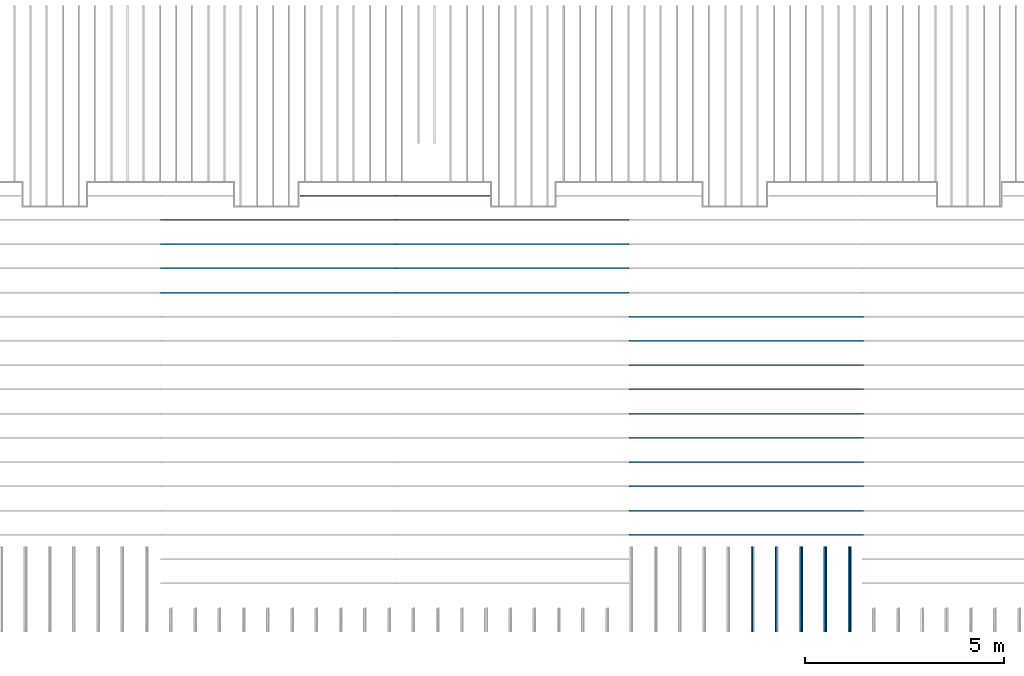
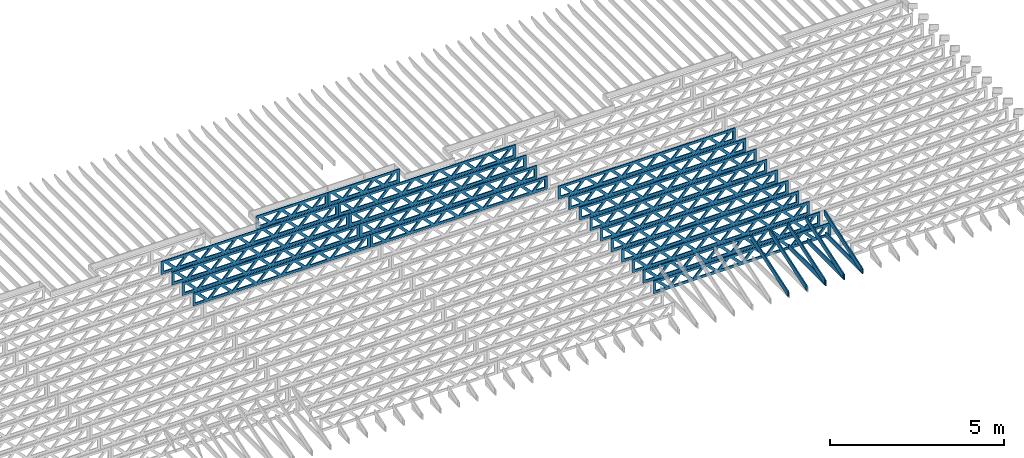
# One storey, part 8 of 17: 28 beams, 5 elements without a shape of their own.
"""IFC4 building model written with IfcOpenShell, lengths in feet."""

from ifc_helpers import new_model, entity, si_unit, converted_unit, derived_unit, direction, frame, frame_2d, origin, origin_2d_with_axis, place, context, subcontext, project, spatial, rectangle, extrude, clip, halfspace, source, transform, mapped, material, material_profile, profile_set, profile_usage, type_object, type_shapes, element, aggregate, save


model = new_model("IFC4")

# Units and contexts
model_context = context("Model", 3, precision=0.0001, world=origin(), true_north=direction((6.12303176911189e-17, 1.0)))
body_context = subcontext(model_context, "Body", "Model", "MODEL_VIEW")
ifc_project = project(units=[converted_unit("LENGTHUNIT", "FOOT", entity("IfcRatioMeasure", 0.3048), si_unit("LENGTHUNIT", "METRE"), dimensions=[1, 0, 0, 0, 0, 0, 0]), converted_unit("AREAUNIT", "SQUARE FOOT", entity("IfcRatioMeasure", 0.09290304), si_unit("AREAUNIT", "SQUARE_METRE"), dimensions=[2, 0, 0, 0, 0, 0, 0]), converted_unit("VOLUMEUNIT", "CUBIC FOOT", entity("IfcRatioMeasure", 0.028316846592), si_unit("VOLUMEUNIT", "CUBIC_METRE"), dimensions=[3, 0, 0, 0, 0, 0, 0]), converted_unit("PLANEANGLEUNIT", "DEGREE", entity("IfcRatioMeasure", 0.0174532925199433), si_unit("PLANEANGLEUNIT", "RADIAN"), dimensions=[0, 0, 0, 0, 0, 0, 0]), si_unit("MASSUNIT", "GRAM", prefix="KILO"), derived_unit("MASSDENSITYUNIT", [(si_unit("MASSUNIT", "GRAM", prefix="KILO"), 1), (si_unit("LENGTHUNIT", "METRE"), -3)]), derived_unit("MOMENTOFINERTIAUNIT", [(si_unit("LENGTHUNIT", "METRE"), 4)]), si_unit("TIMEUNIT", "SECOND"), si_unit("FREQUENCYUNIT", "HERTZ"), si_unit("THERMODYNAMICTEMPERATUREUNIT", "DEGREE_CELSIUS"), derived_unit("THERMALTRANSMITTANCEUNIT", [(si_unit("MASSUNIT", "GRAM", prefix="KILO"), 1), (si_unit("THERMODYNAMICTEMPERATUREUNIT", "KELVIN"), -1), (si_unit("TIMEUNIT", "SECOND"), -3)]), derived_unit("VOLUMETRICFLOWRATEUNIT", [(si_unit("LENGTHUNIT", "METRE"), 3), (si_unit("TIMEUNIT", "SECOND"), -1)]), si_unit("ELECTRICCURRENTUNIT", "AMPERE"), si_unit("ELECTRICVOLTAGEUNIT", "VOLT"), si_unit("POWERUNIT", "WATT"), si_unit("FORCEUNIT", "NEWTON"), si_unit("ILLUMINANCEUNIT", "LUX"), si_unit("LUMINOUSFLUXUNIT", "LUMEN"), si_unit("LUMINOUSINTENSITYUNIT", "CANDELA"), derived_unit("USERDEFINED", [(si_unit("MASSUNIT", "GRAM", prefix="KILO"), -1), (si_unit("LENGTHUNIT", "METRE"), -2), (si_unit("TIMEUNIT", "SECOND"), 3), (si_unit("LUMINOUSFLUXUNIT", "LUMEN"), 1)]), derived_unit("LINEARVELOCITYUNIT", [(si_unit("LENGTHUNIT", "METRE"), 1), (si_unit("TIMEUNIT", "SECOND"), -1)]), si_unit("PRESSUREUNIT", "PASCAL"), derived_unit("USERDEFINED", [(si_unit("LENGTHUNIT", "METRE"), -2), (si_unit("MASSUNIT", "GRAM", prefix="KILO"), 1), (si_unit("TIMEUNIT", "SECOND"), -2)]), derived_unit("LINEARFORCEUNIT", [(si_unit("MASSUNIT", "GRAM", prefix="KILO"), 1), (si_unit("LENGTHUNIT", "METRE"), 1), (si_unit("TIMEUNIT", "SECOND"), -2), (si_unit("LENGTHUNIT", "METRE"), -1)]), derived_unit("PLANARFORCEUNIT", [(si_unit("MASSUNIT", "GRAM", prefix="KILO"), 1), (si_unit("LENGTHUNIT", "METRE"), 1), (si_unit("TIMEUNIT", "SECOND"), -2), (si_unit("LENGTHUNIT", "METRE"), -2)])], contexts=[model_context])

# Site, building, storey
site_placement = place(None, origin())
site = spatial("IfcSite", under=ifc_project, at=site_placement, CompositionType="ELEMENT")
building_placement = place(site_placement, origin())
building = spatial("IfcBuilding", under=site, at=building_placement, CompositionType="ELEMENT")
storey_placement = place(building_placement, frame((0.0, 0.0, 30.4375000000082)))
storey = spatial("IfcBuildingStorey", under=building, at=storey_placement, Name="ROOF", CompositionType="ELEMENT", Elevation=30.4375000000082)

# Assembly, beams
assembly_1_placement = place(storey_placement, origin())
assembly_1 = element("IfcElementAssembly", 1, at=assembly_1_placement, inside=storey, Name="Structural Beam System:Structural Framing System", ObjectType="Structural Beam System:Structural Framing System", AssemblyPlace="NOTDEFINED", PredefinedType="BEAM_GRID")
ifc_material_1 = material(Name="WOOD TRUSS", Category="Materials")
ifc_material_profile_1 = material_profile(ifc_material_1, rectangle(XDim=1.73473973950632, YDim=0.125, at=origin_2d_with_axis()))
ifc_material_profile_2 = material_profile(ifc_material_1, rectangle(XDim=1.73473973950633, YDim=0.125, at=frame_2d((-1.11022302462516e-16, 0.0), x_axis=(1.0, 0.0))))
ifc_material_profile_3 = material_profile(ifc_material_1, rectangle(XDim=1.73473973950632, YDim=0.125, at=origin_2d_with_axis()))
ifc_material_profile_4 = material_profile(ifc_material_1, rectangle(XDim=1.73473973950633, YDim=0.125, at=origin_2d_with_axis()))
ifc_material_profile_5 = material_profile(ifc_material_1, rectangle(XDim=1.73473973950632, YDim=0.125, at=frame_2d((-5.55111512312578e-17, 0.0), x_axis=(1.0, 0.0))))
ifc_material_profile_6 = material_profile(ifc_material_1, rectangle(XDim=1.73473973950633, YDim=0.125, at=frame_2d((-2.77555756156289e-16, 0.0), x_axis=(1.0, 0.0))))
ifc_material_profile_7 = material_profile(ifc_material_1, rectangle(XDim=1.73473973950632, YDim=0.125, at=frame_2d((-4.9960036108132e-16, 0.0), x_axis=(1.0, 0.0))))
ifc_material_profile_8 = material_profile(ifc_material_1, rectangle(XDim=1.73473973950633, YDim=0.125, at=frame_2d((4.44089209850063e-16, 0.0), x_axis=(1.0, 0.0))))
ifc_material_profile_9 = material_profile(ifc_material_1, rectangle(XDim=1.73473973950632, YDim=0.125, at=origin_2d_with_axis()))
ifc_material_profile_10 = material_profile(ifc_material_1, rectangle(XDim=1.73473973950633, YDim=0.125, at=frame_2d((-4.9960036108132e-16, 0.0), x_axis=(1.0, 0.0))))
ifc_material_profile_11 = material_profile(ifc_material_1, rectangle(XDim=0.291666666666664, YDim=0.125, at=frame_2d((-2.77555756156289e-17, 0.0), x_axis=(1.0, 0.0))))
ifc_material_profile_12 = material_profile(ifc_material_1, rectangle(XDim=0.291666666666628, YDim=0.124999999999995, at=frame_2d((-5.55111512312578e-17, 0.0), x_axis=(1.0, 0.0))))
ifc_material_profile_13 = material_profile(ifc_material_1, rectangle(XDim=0.916666666666666, YDim=0.125000000000003, at=frame_2d((-2.77555756156289e-17, 0.0), x_axis=(1.0, 0.0))))
ifc_material_profile_14 = material_profile(ifc_material_1, rectangle(XDim=0.916666666666651, YDim=0.125, at=frame_2d((-2.77555756156289e-17, 0.0), x_axis=(1.0, 0.0))))
ifc_profile_set_1 = profile_set([ifc_material_profile_1, ifc_material_profile_2, ifc_material_profile_3, ifc_material_profile_4, ifc_material_profile_5, ifc_material_profile_6, ifc_material_profile_7, ifc_material_profile_8, ifc_material_profile_9, ifc_material_profile_10, ifc_material_profile_11, ifc_material_profile_12, ifc_material_profile_13, ifc_material_profile_14])
ifc_profile_usage_1 = profile_usage(ifc_profile_set_1, cardinal=8)
beam_type_1 = type_object("IfcBeamType", PredefinedType="BEAM", material=ifc_profile_set_1)
shared_shape_1 = source(origin(), body_context, "Body", "SweptSolid", [
    extrude(rectangle(XDim=1.73473973950632, YDim=0.125, at=frame_2d((-5.55111512312578e-16, 0.0), x_axis=(1.0, 0.0))), frame((5.85339326404794, 0.0, 0.101118361020562), z_axis=(0.720569184836762, 0.0, -0.693383046997606), x_axis=(0.693383046997606, 0.0, 0.720569184836762)), (0.0, 0.0, 1.0), 0.291666666666667),
    extrude(rectangle(XDim=1.73473973950633, YDim=0.125, at=frame_2d((-4.9960036108132e-16, 0.0), x_axis=(1.0, 0.0))), frame((4.60310739037467, 0.0, -0.101118361020407), z_axis=(0.720569184836758, 0.0, 0.69338304699761), x_axis=(0.69338304699761, 0.0, -0.720569184836758)), (0.0, 0.0, 1.0), 0.291666666666667),
    extrude(rectangle(XDim=1.73473973950632, YDim=0.125, at=frame_2d((3.33066907387547e-16, 0.0), x_axis=(1.0, 0.0))), frame((3.18672659738144, 0.0, 0.101118361020562), z_axis=(0.720569184836762, 0.0, -0.693383046997606), x_axis=(0.693383046997606, 0.0, 0.720569184836762)), (0.0, 0.0, 1.0), 0.291666666666667),
    extrude(rectangle(XDim=1.73473973950633, YDim=0.125, at=frame_2d((-1.11022302462516e-16, 0.0), x_axis=(1.0, 0.0))), frame((1.93644072370817, 0.0, -0.101118361020407), z_axis=(0.720569184836758, 0.0, 0.69338304699761), x_axis=(0.69338304699761, 0.0, -0.720569184836758)), (0.0, 0.0, 1.0), 0.291666666666666),
    extrude(rectangle(XDim=1.73473973950632, YDim=0.125, at=frame_2d((5.55111512312578e-17, 0.0), x_axis=(1.0, 0.0))), frame((0.520059930714937, 0.0, 0.101118361020562), z_axis=(0.720569184836762, 0.0, -0.693383046997606), x_axis=(0.693383046997606, 0.0, 0.720569184836762)), (0.0, 0.0, 1.0), 0.291666666666667),
    extrude(rectangle(XDim=1.73473973950633, YDim=0.125, at=origin_2d_with_axis()), frame((-0.730225942958334, 0.0, -0.101118361020407), z_axis=(0.720569184836758, 0.0, 0.69338304699761), x_axis=(0.69338304699761, 0.0, -0.720569184836758)), (0.0, 0.0, 1.0), 0.291666666666666),
    extrude(rectangle(XDim=1.73473973950632, YDim=0.125, at=frame_2d((-5.55111512312578e-17, 0.0), x_axis=(1.0, 0.0))), frame((-2.14660673595157, 0.0, 0.101118361020562), z_axis=(0.720569184836762, 0.0, -0.693383046997606), x_axis=(0.693383046997606, 0.0, 0.720569184836762)), (0.0, 0.0, 1.0), 0.291666666666667),
    extrude(rectangle(XDim=1.73473973950633, YDim=0.125, at=frame_2d((-2.77555756156289e-16, 0.0), x_axis=(1.0, 0.0))), frame((-3.39689260962484, 0.0, -0.101118361020407), z_axis=(0.720569184836758, 0.0, 0.69338304699761), x_axis=(0.69338304699761, 0.0, -0.720569184836758)), (0.0, 0.0, 1.0), 0.291666666666666),
    extrude(rectangle(XDim=1.73473973950632, YDim=0.125, at=origin_2d_with_axis()), frame((-4.81327340261807, 0.0, 0.101118361020562), z_axis=(0.720569184836762, 0.0, -0.693383046997606), x_axis=(0.693383046997606, 0.0, 0.720569184836762)), (0.0, 0.0, 1.0), 0.291666666666667),
    extrude(rectangle(XDim=1.73473973950633, YDim=0.125, at=frame_2d((-4.9960036108132e-16, 0.0), x_axis=(1.0, 0.0))), frame((-6.06355927629134, 0.0, -0.101118361020407), z_axis=(0.720569184836758, 0.0, 0.69338304699761), x_axis=(0.69338304699761, 0.0, -0.720569184836758)), (0.0, 0.0, 1.0), 0.291666666666667),
    extrude(rectangle(XDim=1.73473973950632, YDim=0.125, at=frame_2d((-1.0547118733939e-15, 0.0), x_axis=(1.0, 0.0))), frame((8.52005993071445, 0.0, 0.101118361020506), z_axis=(0.720569184836761, 0.0, -0.693383046997607), x_axis=(0.693383046997607, 0.0, 0.720569184836761)), (0.0, 0.0, 1.0), 0.291666666666667),
    extrude(rectangle(XDim=1.73473973950633, YDim=0.125, at=origin_2d_with_axis()), frame((7.26977405704118, 0.0, -0.101118361020463), z_axis=(0.720569184836758, 0.0, 0.69338304699761), x_axis=(0.69338304699761, 0.0, -0.720569184836758)), (0.0, 0.0, 1.0), 0.291666666666667),
    extrude(rectangle(XDim=1.73473973950632, YDim=0.125, at=frame_2d((4.44089209850063e-16, 0.0), x_axis=(1.0, 0.0))), frame((-7.47994006928457, 0.0, 0.101118361020561), z_axis=(0.720569184836762, 0.0, -0.693383046997606), x_axis=(0.693383046997606, 0.0, 0.720569184836762)), (0.0, 0.0, 1.0), 0.291666666666666),
    extrude(rectangle(XDim=1.73473973950633, YDim=0.125, at=origin_2d_with_axis()), frame((-8.73022594295784, 0.0, -0.101118361020408), z_axis=(0.720569184836758, 0.0, 0.69338304699761), x_axis=(0.69338304699761, 0.0, -0.720569184836758)), (0.0, 0.0, 1.0), 0.291666666666666),
    extrude(rectangle(XDim=0.291666666666664, YDim=0.125, at=frame_2d((-2.77555756156289e-17, 0.0), x_axis=(1.0, 0.0))), frame((-9.66666666666609, 0.0, 0.604166666666611), z_axis=(1.0, 0.0, 0.0), x_axis=(0.0, 0.0, -1.0)), (0.0, 0.0, 1.0), 19.3333333333322),
    extrude(rectangle(XDim=0.291666666666628, YDim=0.124999999999995, at=frame_2d((-5.55111512312578e-17, 0.0), x_axis=(1.0, 0.0))), frame((-9.66666666666588, 0.0, -0.604166666666693), z_axis=(1.0, 0.0, 0.0), x_axis=(0.0, 0.0, -1.0)), (0.0, 0.0, 1.0), 19.333333333332),
    extrude(rectangle(XDim=0.916666666666666, YDim=0.125000000000003, at=frame_2d((-2.77555756156289e-17, 0.0), x_axis=(1.0, 0.0))), frame((9.3749999999994, 0.0, 0.0), z_axis=(1.0, 0.0, 0.0), x_axis=(0.0, 0.0, -1.0)), (0.0, 0.0, 1.0), 0.291666666666687),
    extrude(rectangle(XDim=0.916666666666651, YDim=0.125, at=frame_2d((-2.77555756156289e-17, 0.0), x_axis=(1.0, 0.0))), frame((-9.66666666666609, 0.0, 0.0), z_axis=(1.0, 0.0, 0.0), x_axis=(0.0, 0.0, -1.0)), (0.0, 0.0, 1.0), 0.291666666666687),
])
type_shapes(beam_type_1, [shared_shape_1])
beam_1_placement = place(assembly_1_placement, frame((-174.071493818896, 947.861934882651, 0.74999999999163), z_axis=(0.0, 0.0, 1.0), x_axis=(-1.0, 0.0, 0.0)))
beam_1 = element("IfcBeam", 2, at=beam_1_placement, type_object=beam_type_1, material=ifc_profile_usage_1, PredefinedType="BEAM", context=body_context, shape_type="MappedRepresentation", body=[
    mapped(shared_shape_1, transform((0.0, 0.0, 0.0), scale=1.0)),
])
ifc_profile_usage_2 = profile_usage(ifc_profile_set_1, cardinal=8)
beam_2_placement = place(assembly_1_placement, frame((-174.071493818896, 945.861934882651, 0.749999999991637), z_axis=(0.0, 0.0, 1.0), x_axis=(-1.0, 0.0, 0.0)))
beam_2 = element("IfcBeam", 3, at=beam_2_placement, type_object=beam_type_1, material=ifc_profile_usage_2, PredefinedType="BEAM", context=body_context, shape_type="MappedRepresentation", body=[
    mapped(shared_shape_1, transform((0.0, 0.0, 0.0), scale=1.0)),
])
ifc_profile_usage_3 = profile_usage(ifc_profile_set_1, cardinal=8)
beam_3_placement = place(assembly_1_placement, frame((-174.071493818896, 943.861934882651, 0.749999999991644), z_axis=(0.0, 0.0, 1.0), x_axis=(-1.0, 0.0, 0.0)))
beam_3 = element("IfcBeam", 4, at=beam_3_placement, type_object=beam_type_1, material=ifc_profile_usage_3, PredefinedType="BEAM", context=body_context, shape_type="MappedRepresentation", body=[
    mapped(shared_shape_1, transform((0.0, 0.0, 0.0), scale=1.0)),
])
ifc_profile_usage_4 = profile_usage(ifc_profile_set_1, cardinal=8)
beam_4_placement = place(assembly_1_placement, frame((-174.071493818896, 941.861934882651, 0.749999999991651), z_axis=(0.0, 0.0, 1.0), x_axis=(-1.0, 0.0, 0.0)))
beam_4 = element("IfcBeam", 5, at=beam_4_placement, type_object=beam_type_1, material=ifc_profile_usage_4, PredefinedType="BEAM", context=body_context, shape_type="MappedRepresentation", body=[
    mapped(shared_shape_1, transform((0.0, 0.0, 0.0), scale=1.0)),
])
ifc_profile_usage_5 = profile_usage(ifc_profile_set_1, cardinal=8)
beam_5_placement = place(assembly_1_placement, frame((-174.071493818896, 939.861934882651, 0.749999999991651), z_axis=(0.0, 0.0, 1.0), x_axis=(-1.0, 0.0, 0.0)))
beam_5 = element("IfcBeam", 6, at=beam_5_placement, type_object=beam_type_1, material=ifc_profile_usage_5, PredefinedType="BEAM", context=body_context, shape_type="MappedRepresentation", body=[
    mapped(shared_shape_1, transform((0.0, 0.0, 0.0), scale=1.0)),
])
ifc_profile_usage_6 = profile_usage(ifc_profile_set_1, cardinal=8)
beam_6_placement = place(assembly_1_placement, frame((-174.071493818896, 937.861934882651, 0.749999999991658), z_axis=(0.0, 0.0, 1.0), x_axis=(-1.0, 0.0, 0.0)))
beam_6 = element("IfcBeam", 7, at=beam_6_placement, type_object=beam_type_1, material=ifc_profile_usage_6, PredefinedType="BEAM", context=body_context, shape_type="MappedRepresentation", body=[
    mapped(shared_shape_1, transform((0.0, 0.0, 0.0), scale=1.0)),
])
ifc_profile_usage_7 = profile_usage(ifc_profile_set_1, cardinal=8)
beam_7_placement = place(assembly_1_placement, frame((-174.071493818896, 935.861934882651, 0.749999999991665), z_axis=(0.0, 0.0, 1.0), x_axis=(-1.0, 0.0, 0.0)))
beam_7 = element("IfcBeam", 8, at=beam_7_placement, type_object=beam_type_1, material=ifc_profile_usage_7, PredefinedType="BEAM", context=body_context, shape_type="MappedRepresentation", body=[
    mapped(shared_shape_1, transform((0.0, 0.0, 0.0), scale=1.0)),
])
ifc_profile_usage_8 = profile_usage(ifc_profile_set_1, cardinal=8)
beam_8_placement = place(assembly_1_placement, frame((-174.071493818896, 933.861934882651, 0.749999999991672), z_axis=(0.0, 0.0, 1.0), x_axis=(-1.0, 0.0, 0.0)))
beam_8 = element("IfcBeam", 9, at=beam_8_placement, type_object=beam_type_1, material=ifc_profile_usage_8, PredefinedType="BEAM", context=body_context, shape_type="MappedRepresentation", body=[
    mapped(shared_shape_1, transform((0.0, 0.0, 0.0), scale=1.0)),
])
ifc_profile_usage_9 = profile_usage(ifc_profile_set_1, cardinal=8)
beam_9_placement = place(assembly_1_placement, frame((-174.071493818896, 931.861934882651, 0.74999999999168), z_axis=(0.0, 0.0, 1.0), x_axis=(-1.0, 0.0, 0.0)))
beam_9 = element("IfcBeam", 10, at=beam_9_placement, type_object=beam_type_1, material=ifc_profile_usage_9, PredefinedType="BEAM", context=body_context, shape_type="MappedRepresentation", body=[
    mapped(shared_shape_1, transform((0.0, 0.0, 0.0), scale=1.0)),
])
ifc_profile_usage_10 = profile_usage(ifc_profile_set_1, cardinal=8)
beam_10_placement = place(assembly_1_placement, frame((-174.071493818896, 929.861934882651, 0.74999999999168), z_axis=(0.0, 0.0, 1.0), x_axis=(-1.0, 0.0, 0.0)))
beam_10 = element("IfcBeam", 11, at=beam_10_placement, type_object=beam_type_1, material=ifc_profile_usage_10, PredefinedType="BEAM", context=body_context, shape_type="MappedRepresentation", body=[
    mapped(shared_shape_1, transform((0.0, 0.0, 0.0), scale=1.0)),
])
aggregate(assembly_1, [beam_1, beam_2, beam_3, beam_4, beam_5, beam_6, beam_7, beam_8, beam_9, beam_10])

assembly_2_placement = place(storey_placement, origin())
assembly_2 = element("IfcElementAssembly", 12, at=assembly_2_placement, inside=storey, Name="Structural Beam System:Structural Framing System", ObjectType="Structural Beam System:Structural Framing System", AssemblyPlace="NOTDEFINED", PredefinedType="BEAM_GRID")
ifc_profile_usage_11 = profile_usage(ifc_profile_set_1, cardinal=8)
beam_11_placement = place(assembly_2_placement, frame((-193.404827152229, 955.861934882651, 0.749999999991601)))
beam_11 = element("IfcBeam", 13, at=beam_11_placement, type_object=beam_type_1, material=ifc_profile_usage_11, PredefinedType="BEAM", context=body_context, shape_type="MappedRepresentation", body=[
    mapped(shared_shape_1, transform((0.0, 0.0, 0.0), scale=1.0)),
])
ifc_profile_usage_12 = profile_usage(ifc_profile_set_1, cardinal=8)
beam_12_placement = place(assembly_2_placement, frame((-193.404827152229, 953.861934882651, 0.749999999991601)))
beam_12 = element("IfcBeam", 14, at=beam_12_placement, type_object=beam_type_1, material=ifc_profile_usage_12, PredefinedType="BEAM", context=body_context, shape_type="MappedRepresentation", body=[
    mapped(shared_shape_1, transform((0.0, 0.0, 0.0), scale=1.0)),
])
ifc_profile_usage_13 = profile_usage(ifc_profile_set_1, cardinal=8)
beam_13_placement = place(assembly_2_placement, frame((-193.404827152229, 951.861934882651, 0.749999999991608)))
beam_13 = element("IfcBeam", 15, at=beam_13_placement, type_object=beam_type_1, material=ifc_profile_usage_13, PredefinedType="BEAM", context=body_context, shape_type="MappedRepresentation", body=[
    mapped(shared_shape_1, transform((0.0, 0.0, 0.0), scale=1.0)),
])
ifc_profile_usage_14 = profile_usage(ifc_profile_set_1, cardinal=8)
beam_14_placement = place(assembly_2_placement, frame((-193.404827152229, 949.861934882651, 0.749999999991616)))
beam_14 = element("IfcBeam", 16, at=beam_14_placement, type_object=beam_type_1, material=ifc_profile_usage_14, PredefinedType="BEAM", context=body_context, shape_type="MappedRepresentation", body=[
    mapped(shared_shape_1, transform((0.0, 0.0, 0.0), scale=1.0)),
])

assembly_3_placement = place(storey_placement, origin())
assembly_3 = element("IfcElementAssembly", 17, at=assembly_3_placement, inside=storey, Name="Structural Beam System:Structural Framing System", ObjectType="Structural Beam System:Structural Framing System", AssemblyPlace="NOTDEFINED", PredefinedType="BEAM_GRID")
ifc_profile_usage_15 = profile_usage(ifc_profile_set_1, cardinal=8)
beam_15_placement = place(assembly_3_placement, frame((-212.738160485494, 955.861934882651, 0.749999999991601), z_axis=(0.0, 0.0, 1.0), x_axis=(-1.0, 0.0, 0.0)))
beam_15 = element("IfcBeam", 18, at=beam_15_placement, type_object=beam_type_1, material=ifc_profile_usage_15, PredefinedType="BEAM", context=body_context, shape_type="MappedRepresentation", body=[
    mapped(shared_shape_1, transform((0.0, 0.0, 0.0), scale=1.0)),
])
ifc_profile_usage_16 = profile_usage(ifc_profile_set_1, cardinal=8)
beam_16_placement = place(assembly_3_placement, frame((-212.738160485494, 953.861934882651, 0.749999999991601), z_axis=(0.0, 0.0, 1.0), x_axis=(-1.0, 0.0, 0.0)))
beam_16 = element("IfcBeam", 19, at=beam_16_placement, type_object=beam_type_1, material=ifc_profile_usage_16, PredefinedType="BEAM", context=body_context, shape_type="MappedRepresentation", body=[
    mapped(shared_shape_1, transform((0.0, 0.0, 0.0), scale=1.0)),
])
ifc_profile_usage_17 = profile_usage(ifc_profile_set_1, cardinal=8)
beam_17_placement = place(assembly_3_placement, frame((-212.738160485494, 951.861934882651, 0.749999999991608), z_axis=(0.0, 0.0, 1.0), x_axis=(-1.0, 0.0, 0.0)))
beam_17 = element("IfcBeam", 20, at=beam_17_placement, type_object=beam_type_1, material=ifc_profile_usage_17, PredefinedType="BEAM", context=body_context, shape_type="MappedRepresentation", body=[
    mapped(shared_shape_1, transform((0.0, 0.0, 0.0), scale=1.0)),
])
ifc_profile_usage_18 = profile_usage(ifc_profile_set_1, cardinal=8)
beam_18_placement = place(assembly_3_placement, frame((-212.738160485494, 949.861934882651, 0.749999999991616), z_axis=(0.0, 0.0, 1.0), x_axis=(-1.0, 0.0, 0.0)))
beam_18 = element("IfcBeam", 21, at=beam_18_placement, type_object=beam_type_1, material=ifc_profile_usage_18, PredefinedType="BEAM", context=body_context, shape_type="MappedRepresentation", body=[
    mapped(shared_shape_1, transform((0.0, 0.0, 0.0), scale=1.0)),
])

# Beam
ifc_profile_usage_19 = profile_usage(ifc_profile_set_1, cardinal=8)
beam_type_2 = type_object("IfcBeamType", PredefinedType="BEAM", material=ifc_profile_set_1)
shared_shape_2 = source(origin(), body_context, "Body", "SweptSolid", [
    extrude(rectangle(XDim=1.73473973950632, YDim=0.125, at=origin_2d_with_axis()), frame((0.520059930714935, 0.0, 0.101118361020562), z_axis=(0.720569184836762, 0.0, -0.693383046997606), x_axis=(0.693383046997606, 0.0, 0.720569184836762)), (0.0, 0.0, 1.0), 0.291666666666667),
    extrude(rectangle(XDim=1.73473973950633, YDim=0.125, at=origin_2d_with_axis()), frame((-0.730225942958335, 0.0, -0.101118361020407), z_axis=(0.720569184836758, 0.0, 0.69338304699761), x_axis=(0.69338304699761, 0.0, -0.720569184836758)), (0.0, 0.0, 1.0), 0.291666666666666),
    extrude(rectangle(XDim=1.73473973950632, YDim=0.125, at=origin_2d_with_axis()), frame((2.77005984700217, 0.0, 0.101118361020514), z_axis=(0.720569184836762, 0.0, -0.693383046997606), x_axis=(0.693383046997606, 0.0, 0.720569184836762)), (0.0, 0.0, 1.0), 0.291666666666667),
    extrude(rectangle(XDim=1.73473973950633, YDim=0.125, at=frame_2d((-1.11022302462516e-16, 0.0), x_axis=(1.0, 0.0))), frame((1.5197739733289, 0.0, -0.101118361020455), z_axis=(0.720569184836758, 0.0, 0.69338304699761), x_axis=(0.69338304699761, 0.0, -0.720569184836758)), (0.0, 0.0, 1.0), 0.291666666666666),
    extrude(rectangle(XDim=1.73473973950632, YDim=0.125, at=frame_2d((-5.55111512312578e-17, 0.0), x_axis=(1.0, 0.0))), frame((-1.7299399855723, 0.0, 0.101118361020555), z_axis=(0.720569184836762, 0.0, -0.693383046997606), x_axis=(0.693383046997606, 0.0, 0.720569184836762)), (0.0, 0.0, 1.0), 0.291666666666667),
    extrude(rectangle(XDim=1.73473973950633, YDim=0.125, at=frame_2d((-2.77555756156289e-16, 0.0), x_axis=(1.0, 0.0))), frame((-2.98022585924557, 0.0, -0.101118361020414), z_axis=(0.720569184836758, 0.0, 0.69338304699761), x_axis=(0.69338304699761, 0.0, -0.720569184836758)), (0.0, 0.0, 1.0), 0.291666666666666),
    extrude(rectangle(XDim=0.291666666666664, YDim=0.125, at=frame_2d((-2.77555756156289e-17, 0.0), x_axis=(1.0, 0.0))), frame((-3.91666658295382, 0.0, 0.604166666666611), z_axis=(1.0, 0.0, 0.0), x_axis=(0.0, 0.0, -1.0)), (0.0, 0.0, 1.0), 7.83333316590765),
    extrude(rectangle(XDim=0.291666666666628, YDim=0.124999999999995, at=frame_2d((-5.55111512312578e-17, 0.0), x_axis=(1.0, 0.0))), frame((-3.91666658295361, 0.0, -0.604166666666693), z_axis=(1.0, 0.0, 0.0), x_axis=(0.0, 0.0, -1.0)), (0.0, 0.0, 1.0), 7.83333316590743),
    extrude(rectangle(XDim=0.916666666666666, YDim=0.125000000000003, at=frame_2d((-2.77555756156289e-17, 0.0), x_axis=(1.0, 0.0))), frame((3.62499991628714, 0.0, 0.0), z_axis=(1.0, 0.0, 0.0), x_axis=(0.0, 0.0, -1.0)), (0.0, 0.0, 1.0), 0.291666666666687),
    extrude(rectangle(XDim=0.916666666666651, YDim=0.125, at=frame_2d((-2.77555756156289e-17, 0.0), x_axis=(1.0, 0.0))), frame((-3.91666658295382, 0.0, 0.0), z_axis=(1.0, 0.0, 0.0), x_axis=(0.0, 0.0, -1.0)), (0.0, 0.0, 1.0), 0.291666666666687),
])
type_shapes(beam_type_2, [shared_shape_2])
beam_19_placement = place(assembly_2_placement, frame((-199.154827235941, 957.861934882651, 0.749999999991587)))
beam_19 = element("IfcBeam", 22, at=beam_19_placement, type_object=beam_type_2, material=ifc_profile_usage_19, PredefinedType="BEAM", context=body_context, shape_type="MappedRepresentation", body=[
    mapped(shared_shape_2, transform((0.0, 0.0, 0.0), scale=1.0)),
])

aggregate(assembly_2, [beam_19, beam_11, beam_12, beam_13, beam_14])

ifc_profile_usage_20 = profile_usage(ifc_profile_set_1, cardinal=8)
beam_20_placement = place(assembly_3_placement, frame((-206.988160401782, 957.861934882651, 0.749999999991587), z_axis=(0.0, 0.0, 1.0), x_axis=(-1.0, 0.0, 0.0)))
beam_20 = element("IfcBeam", 23, at=beam_20_placement, type_object=beam_type_2, material=ifc_profile_usage_20, PredefinedType="BEAM", context=body_context, shape_type="MappedRepresentation", body=[
    mapped(shared_shape_2, transform((0.0, 0.0, 0.0), scale=1.0)),
])

aggregate(assembly_3, [beam_20, beam_15, beam_16, beam_17, beam_18])

# Assembly, beams
assembly_4_placement = place(storey_placement, origin())
assembly_4 = element("IfcElementAssembly", 24, at=assembly_4_placement, inside=storey, Name="Structural Beam System:Structural Framing System", ObjectType="Structural Beam System:Structural Framing System", AssemblyPlace="NOTDEFINED", PredefinedType="BEAM_GRID")
ifc_material_2 = material(Name="BOTTOM CHORD OF FIELD FRAMED OVERHANG", Category="Materials")
ifc_material_profile_15 = material_profile(ifc_material_2, rectangle(XDim=0.604166666666667, YDim=0.125000000000011, at=origin_2d_with_axis()), Name="2X8 - BOTTOM CHORD")
ifc_profile_set_2 = profile_set([ifc_material_profile_15], Name="2X8 - BOTTOM CHORD")
ifc_profile_usage_21 = profile_usage(ifc_profile_set_2, cardinal=8)
beam_type_3 = type_object("IfcBeamType", Name="061100 - Wood Framing:2X8 - BOTTOM CHORD", PredefinedType="BEAM", material=ifc_profile_set_2)
shared_shape_3 = source(origin(), body_context, "Body", "SweptSolid", [
    extrude(rectangle(XDim=0.604166666666667, YDim=0.125000000000011, at=origin_2d_with_axis()), frame((-3.49999999999926, 0.0, 0.0), z_axis=(1.0, 0.0, 0.0), x_axis=(0.0, 0.0, -1.0)), (0.0, 0.0, 1.0), 6.99999999999852),
])
type_shapes(beam_type_3, [shared_shape_3])
beam_21_placement = place(assembly_4_placement, frame((-165.488158437574, 925.361944325417, 1.07291666665406), z_axis=(0.0, 0.0, 1.0), x_axis=(0.0, -1.0, 0.0)))
beam_21 = element("IfcBeam", 25, at=beam_21_placement, type_object=beam_type_3, material=ifc_profile_usage_21, Name="061100 - Wood Framing:2X8 - BOTTOM CHORD", ObjectType="061100 - Wood Framing:2X8 - BOTTOM CHORD", PredefinedType="BEAM", context=body_context, shape_type="MappedRepresentation", body=[
    mapped(shared_shape_3, transform((0.0, 0.0, 0.0), scale=1.0)),
])
ifc_profile_usage_22 = profile_usage(ifc_profile_set_2, cardinal=8)
beam_22_placement = place(assembly_4_placement, frame((-167.488158437574, 925.361943822913, 1.07291666665406), z_axis=(0.0, 0.0, 1.0), x_axis=(0.0, -1.0, 0.0)))
beam_22 = element("IfcBeam", 26, at=beam_22_placement, type_object=beam_type_3, material=ifc_profile_usage_22, Name="061100 - Wood Framing:2X8 - BOTTOM CHORD", ObjectType="061100 - Wood Framing:2X8 - BOTTOM CHORD", PredefinedType="BEAM", context=body_context, shape_type="MappedRepresentation", body=[
    mapped(shared_shape_3, transform((0.0, 0.0, 0.0), scale=1.0)),
])
ifc_profile_usage_23 = profile_usage(ifc_profile_set_2, cardinal=8)
beam_23_placement = place(assembly_4_placement, frame((-169.488158437574, 925.361943320409, 1.07291666665406), z_axis=(0.0, 0.0, 1.0), x_axis=(0.0, -1.0, 0.0)))
beam_23 = element("IfcBeam", 27, at=beam_23_placement, type_object=beam_type_3, material=ifc_profile_usage_23, Name="061100 - Wood Framing:2X8 - BOTTOM CHORD", ObjectType="061100 - Wood Framing:2X8 - BOTTOM CHORD", PredefinedType="BEAM", context=body_context, shape_type="MappedRepresentation", body=[
    mapped(shared_shape_3, transform((0.0, 0.0, 0.0), scale=1.0)),
])
aggregate(assembly_4, [beam_21, beam_22, beam_23])

assembly_5_placement = place(storey_placement, origin())
assembly_5 = element("IfcElementAssembly", 28, at=assembly_5_placement, inside=storey, Name="Structural Beam System:Structural Framing System", ObjectType="Structural Beam System:Structural Framing System", AssemblyPlace="NOTDEFINED", PredefinedType="BEAM_GRID")
ifc_material_3 = material(Name="TOP CHORD OF FIELD FRAMED OVERHANG", Category="Materials")
ifc_material_profile_16 = material_profile(ifc_material_3, rectangle(XDim=0.604166666666667, YDim=0.125, at=origin_2d_with_axis()), Name="2X8 TOP CHORD")
ifc_profile_set_3 = profile_set([ifc_material_profile_16], Name="2X8 TOP CHORD")
ifc_profile_usage_24 = profile_usage(ifc_profile_set_3, cardinal=8)
beam_type_4 = type_object("IfcBeamType", Name="Dimension Lumber - Ends:2X8 TOP CHORD", PredefinedType="BEAM", material=ifc_profile_set_3)
shared_shape_4 = source(origin(), body_context, "Body", "Clipping", [
    clip(clip(extrude(rectangle(XDim=0.604166666666667, YDim=0.125, at=origin_2d_with_axis()), frame((-3.68931731846402, 0.0, 0.0), z_axis=(1.0, 0.0, 0.0), x_axis=(0.0, 0.0, -1.0)), (0.0, 0.0, 1.0), 7.5799655454405), halfspace(frame((3.68931731846399, -0.0625000000000025, -0.302083333333339), z_axis=(0.948710608132914, 0.0, -0.316145823973806), x_axis=(0.0, 1.0, 0.0)), False)), halfspace(frame((-3.48798640995154, -0.0625000000000025, 0.302083333333328), z_axis=(-0.948710608132914, 0.0, 0.316145823973807), x_axis=(0.0, 1.0, 0.0)), False)),
])
type_shapes(beam_type_4, [shared_shape_4])
beam_24_placement = place(assembly_5_placement, frame((-165.613158541547, 925.266385711858, 2.43688541345608), z_axis=(0.0, -0.31622776601685, 0.94868329805051), x_axis=(0.0, 0.94868329805051, 0.31622776601685)))
beam_24 = element("IfcBeam", 29, at=beam_24_placement, type_object=beam_type_4, material=ifc_profile_usage_24, Name="Dimension Lumber - Ends:2X8 TOP CHORD", ObjectType="Dimension Lumber - Ends:2X8 TOP CHORD", PredefinedType="BEAM", context=body_context, shape_type="MappedRepresentation", body=[
    mapped(shared_shape_4, transform((0.0, 0.0, 0.0), scale=1.0)),
])
ifc_profile_usage_25 = profile_usage(ifc_profile_set_3, cardinal=8)
beam_25_placement = place(assembly_5_placement, frame((-167.613158541547, 925.266385711858, 2.43688541345608), z_axis=(0.0, -0.316227766016849, 0.94868329805051), x_axis=(0.0, 0.94868329805051, 0.316227766016849)))
beam_25 = element("IfcBeam", 30, at=beam_25_placement, type_object=beam_type_4, material=ifc_profile_usage_25, Name="Dimension Lumber - Ends:2X8 TOP CHORD", ObjectType="Dimension Lumber - Ends:2X8 TOP CHORD", PredefinedType="BEAM", context=body_context, shape_type="MappedRepresentation", body=[
    mapped(shared_shape_4, transform((0.0, 0.0, 0.0), scale=1.0)),
])
ifc_profile_usage_26 = profile_usage(ifc_profile_set_3, cardinal=8)
beam_26_placement = place(assembly_5_placement, frame((-169.613158541547, 925.266385711858, 2.43688541345608), z_axis=(0.0, -0.316227766016849, 0.94868329805051), x_axis=(0.0, 0.94868329805051, 0.316227766016849)))
beam_26 = element("IfcBeam", 31, at=beam_26_placement, type_object=beam_type_4, material=ifc_profile_usage_26, Name="Dimension Lumber - Ends:2X8 TOP CHORD", ObjectType="Dimension Lumber - Ends:2X8 TOP CHORD", PredefinedType="BEAM", context=body_context, shape_type="MappedRepresentation", body=[
    mapped(shared_shape_4, transform((0.0, 0.0, 0.0), scale=1.0)),
])
ifc_profile_usage_27 = profile_usage(ifc_profile_set_3, cardinal=8)
beam_27_placement = place(assembly_5_placement, frame((-171.613158541547, 925.266385711858, 2.43688541345614), z_axis=(0.0, -0.31622776601685, 0.94868329805051), x_axis=(0.0, 0.94868329805051, 0.31622776601685)))
beam_27 = element("IfcBeam", 32, at=beam_27_placement, type_object=beam_type_4, material=ifc_profile_usage_27, Name="Dimension Lumber - Ends:2X8 TOP CHORD", ObjectType="Dimension Lumber - Ends:2X8 TOP CHORD", PredefinedType="BEAM", context=body_context, shape_type="MappedRepresentation", body=[
    mapped(shared_shape_4, transform((0.0, 0.0, 0.0), scale=1.0)),
])
ifc_profile_usage_28 = profile_usage(ifc_profile_set_3, cardinal=8)
beam_28_placement = place(assembly_5_placement, frame((-173.613158541547, 925.266385711858, 2.4368854134562), z_axis=(0.0, -0.316227766016849, 0.94868329805051), x_axis=(0.0, 0.94868329805051, 0.316227766016849)))
beam_28 = element("IfcBeam", 33, at=beam_28_placement, type_object=beam_type_4, material=ifc_profile_usage_28, Name="Dimension Lumber - Ends:2X8 TOP CHORD", ObjectType="Dimension Lumber - Ends:2X8 TOP CHORD", PredefinedType="BEAM", context=body_context, shape_type="MappedRepresentation", body=[
    mapped(shared_shape_4, transform((0.0, 0.0, 0.0), scale=1.0)),
])
aggregate(assembly_5, [beam_24, beam_25, beam_26, beam_27, beam_28])

save(model, "model.ifc")
